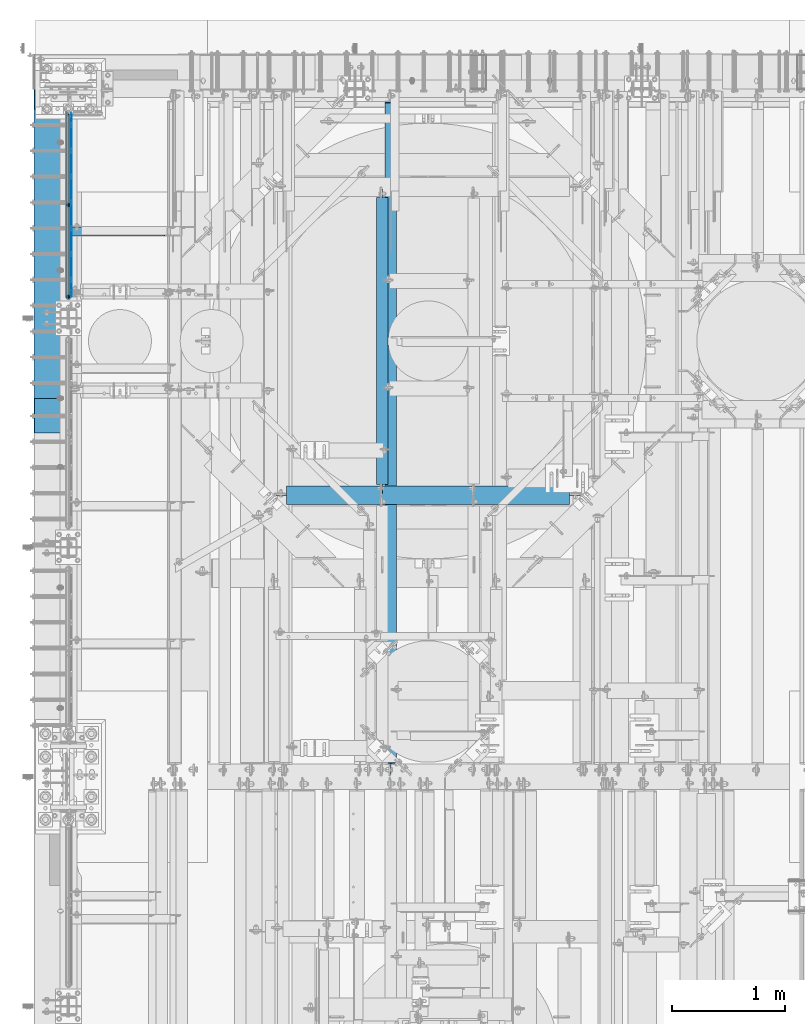
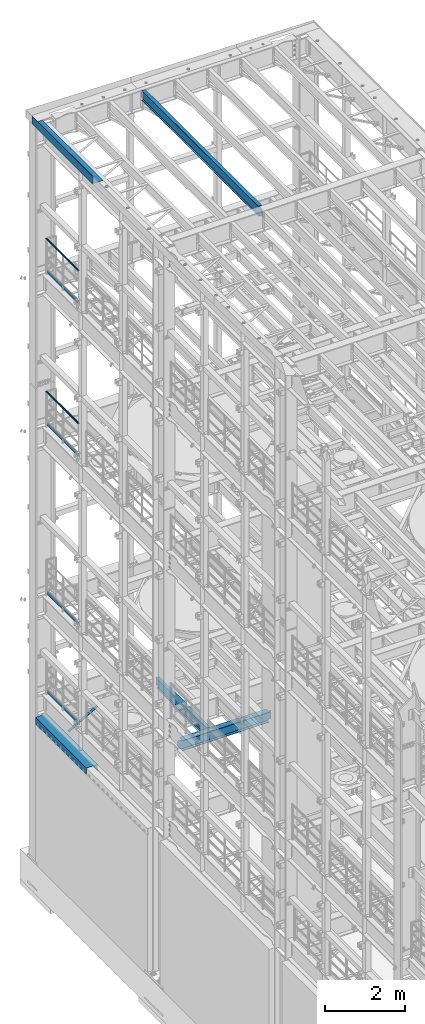
# One storey, part 1052 of 1876: 11 beams, 1 member, 10 elements without a shape of their own.
"""IFC2X3 building model written with IfcOpenShell, lengths in millimetres."""

from ifc_helpers import new_model, si_unit, frame, origin_with_axes, place, context, subcontext, project, spatial, faceted_brep, material, type_object, element, aggregate, save


model = new_model("IFC2X3")

# Units and contexts
model_context = context("Model", 3, precision=1e-05, world=origin_with_axes())
body_context = subcontext(model_context, "Body", "Model", "MODEL_VIEW")
ifc_project = project(units=[si_unit("LENGTHUNIT", "METRE", prefix="MILLI"), si_unit("AREAUNIT", "SQUARE_METRE"), si_unit("VOLUMEUNIT", "CUBIC_METRE"), si_unit("MASSUNIT", "GRAM", prefix="KILO"), si_unit("TIMEUNIT", "SECOND"), si_unit("PLANEANGLEUNIT", "RADIAN"), si_unit("SOLIDANGLEUNIT", "STERADIAN"), si_unit("THERMODYNAMICTEMPERATUREUNIT", "DEGREE_CELSIUS"), si_unit("LUMINOUSINTENSITYUNIT", "LUMEN")], contexts=[model_context])

# Site, building, storey
site_placement = place(None, origin_with_axes())
site = spatial("IfcSite", under=ifc_project, at=site_placement, CompositionType="ELEMENT")
building_placement = place(site_placement, origin_with_axes())
building = spatial("IfcBuilding", under=site, at=building_placement, Name="Undefined", CompositionType="ELEMENT")
storey_placement = place(building_placement, origin_with_axes())
storey = spatial("IfcBuildingStorey", under=building, at=storey_placement, Name="Undefined", CompositionType="ELEMENT", Elevation=0.0)

# Assembly, beam
assembly_1_placement = place(storey_placement, origin_with_axes())
assembly_1 = element("IfcElementAssembly", 1, at=assembly_1_placement, inside=storey, Name="RAIL", AssemblyPlace="NOTDEFINED", PredefinedType="RIGID_FRAME")
ifc_material_1 = material()
beam_type_1 = type_object("IfcBeamType", Name="PIPE1-1/2SCH40", PredefinedType="NOTDEFINED")
beam_1_placement = place(assembly_1_placement, frame((-1.70530256582424e-11, 11848.7825, 19059.525), z_axis=(0.0, 0.0, -1.0), x_axis=(0.0, 1.0, 0.0)))
beam_1 = element("IfcBeam", 2, at=beam_1_placement, type_object=beam_type_1, material=ifc_material_1, Name="RAIL", ObjectType="PIPE1-1/2SCH40", context=body_context, shape_type="Brep", body=[
    faceted_brep([(24.1300000000001, -20.4469999999999, 0.0), (34.3535000000002, -17.7076214311803, 10.2235000000001), (1668.63142143118, -17.7076214311804, 10.2235000000001), (1671.3708, -20.447, 0.0), (41.8376214311802, -10.2235000000001, 17.7076214311819), (1661.1473, -10.2235, 17.7076214311819), (44.5770000000002, 0.0, 20.4470000000001), (1650.9238, 0.0, 20.4470000000001), (41.8376214311802, 10.2235000000001, 17.7076214311819), (1640.7003, 10.2235, 17.7076214311819), (34.3535000000002, 17.7076214311803, 10.2235000000001), (1633.21617856882, 17.7076214311804, 10.2235000000001), (24.1300000000001, 20.4469999999999, 0.0), (1630.4768, 20.447, 0.0), (13.9065000000001, 17.7076214311803, -10.2235000000001), (1633.21617856882, 17.7076214311804, -10.2235000000001), (6.42237856882002, 10.2235000000001, -17.7076214311819), (1640.7003, 10.2235, -17.7076214311819), (3.68299999999999, 0.0, -20.4470000000001), (1650.9238, 0.0, -20.4470000000001), (6.42237856882002, -10.2235000000001, -17.7076214311819), (1661.1473, -10.2235, -17.7076214311819), (13.9065000000001, -17.7076214311803, -10.2235000000001), (1668.63142143118, -17.7076214311804, -10.2235000000001), (24.1299999999854, -24.1299999999992, 0.0), (12.0650000000064, -20.8971929933177, -12.0649999999987), (1671.82099299332, -20.8971929933185, -12.0649999999987), (1675.0538, -24.13, 0.0), (3.23280700668147, -12.0650000000001, -20.8971929933177), (1662.9888, -12.065, -20.8971929933177), (-1.45519152283669e-11, 0.0, -24.130000000001), (1650.9238, 0.0, -24.130000000001), (3.23280700668147, 12.0650000000001, -20.8971929933177), (1638.8588, 12.065, -20.8971929933177), (12.0650000000064, 20.8971929933177, -12.0649999999987), (1630.02660700668, 20.8971929933185, -12.0649999999987), (24.1300000000047, 24.1299999999992, 0.0), (1626.7938, 24.13, 0.0), (36.1949999999997, 20.8971929933184, 12.0649999999987), (1630.02660700668, 20.8971929933185, 12.0649999999987), (45.0271929933187, 12.0650000000001, 20.8971929933177), (1638.8588, 12.065, 20.8971929933177), (48.2600000000002, 0.0, 24.130000000001), (1650.9238, 0.0, 24.130000000001), (45.0271929933187, -12.0650000000001, 20.8971929933177), (1662.9888, -12.065, 20.8971929933177), (36.1949999999997, -20.8971929933184, 12.0649999999987), (1671.82099299332, -20.8971929933185, 12.0649999999987)], [[[0, 1, 2, 3]], [[1, 4, 5, 2]], [[4, 6, 7, 5]], [[6, 8, 9, 7]], [[8, 10, 11, 9]], [[10, 12, 13, 11]], [[12, 14, 15, 13]], [[14, 16, 17, 15]], [[16, 18, 19, 17]], [[18, 20, 21, 19]], [[20, 22, 23, 21]], [[22, 0, 3, 23]], [[24, 25, 26, 27]], [[25, 28, 29, 26]], [[28, 30, 31, 29]], [[30, 32, 33, 31]], [[32, 34, 35, 33]], [[34, 36, 37, 35]], [[36, 38, 39, 37]], [[38, 40, 41, 39]], [[40, 42, 43, 41]], [[42, 44, 45, 43]], [[44, 46, 47, 45]], [[46, 24, 27, 47]], [[29, 31, 33, 35, 37, 39, 41, 43, 45, 47, 27, 26], [5, 7, 9, 11, 13, 15, 17, 19, 21, 23, 3, 2]], [[46, 44, 42, 40, 38, 36, 34, 32, 30, 28, 25, 24], [22, 20, 18, 16, 14, 12, 10, 8, 6, 4, 1, 0]]]),
])

assembly_2_placement = place(storey_placement, origin_with_axes())
assembly_2 = element("IfcElementAssembly", 3, at=assembly_2_placement, inside=storey, Name="RAIL", AssemblyPlace="NOTDEFINED", PredefinedType="RIGID_FRAME")
beam_2_placement = place(assembly_2_placement, frame((-3.29691829392686e-11, 11848.7825, 14385.925), z_axis=(0.0, 0.0, -1.0), x_axis=(0.0, 1.0, 0.0)))
beam_2 = element("IfcBeam", 4, at=beam_2_placement, type_object=beam_type_1, material=ifc_material_1, Name="RAIL", ObjectType="PIPE1-1/2SCH40", context=body_context, shape_type="Brep", body=[
    faceted_brep([(24.1300000000001, -20.4469999999999, 0.0), (34.3535000000002, -17.7076214311803, 10.2235000000001), (1668.63142143118, -17.7076214311804, 10.2235000000001), (1671.3708, -20.447, 0.0), (41.8376214311802, -10.2235000000001, 17.7076214311819), (1661.1473, -10.2235, 17.7076214311819), (44.5770000000002, 0.0, 20.4470000000001), (1650.9238, 0.0, 20.4470000000001), (41.8376214311802, 10.2235000000001, 17.7076214311819), (1640.7003, 10.2235, 17.7076214311819), (34.3535000000002, 17.7076214311803, 10.2235000000001), (1633.21617856882, 17.7076214311804, 10.2235000000001), (24.1300000000001, 20.4469999999999, 0.0), (1630.4768, 20.447, 0.0), (13.9065000000001, 17.7076214311803, -10.2235000000001), (1633.21617856882, 17.7076214311804, -10.2235000000001), (6.42237856882002, 10.2235000000001, -17.7076214311819), (1640.7003, 10.2235, -17.7076214311819), (3.68299999999999, 0.0, -20.4470000000001), (1650.9238, 0.0, -20.4470000000001), (6.42237856882002, -10.2235000000001, -17.7076214311819), (1661.1473, -10.2235, -17.7076214311819), (13.9065000000001, -17.7076214311803, -10.2235000000001), (1668.63142143118, -17.7076214311804, -10.2235000000001), (24.1299999999854, -24.1299999999992, 0.0), (12.0650000000064, -20.8971929933177, -12.0649999999987), (1671.82099299332, -20.8971929933185, -12.0649999999987), (1675.0538, -24.13, 0.0), (3.23280700668147, -12.0650000000001, -20.8971929933177), (1662.9888, -12.065, -20.8971929933177), (-1.45519152283669e-11, 0.0, -24.130000000001), (1650.9238, 0.0, -24.130000000001), (3.23280700668147, 12.0650000000001, -20.8971929933177), (1638.8588, 12.065, -20.8971929933177), (12.0650000000064, 20.8971929933177, -12.0649999999987), (1630.02660700668, 20.8971929933185, -12.0649999999987), (24.1300000000047, 24.1299999999992, 0.0), (1626.7938, 24.13, 0.0), (36.1949999999997, 20.8971929933184, 12.0649999999987), (1630.02660700668, 20.8971929933185, 12.0649999999987), (45.0271929933187, 12.0650000000001, 20.8971929933177), (1638.8588, 12.065, 20.8971929933177), (48.2600000000002, 0.0, 24.130000000001), (1650.9238, 0.0, 24.130000000001), (45.0271929933187, -12.0650000000001, 20.8971929933177), (1662.9888, -12.065, 20.8971929933177), (36.1949999999997, -20.8971929933184, 12.0649999999987), (1671.82099299332, -20.8971929933185, 12.0649999999987)], [[[0, 1, 2, 3]], [[1, 4, 5, 2]], [[4, 6, 7, 5]], [[6, 8, 9, 7]], [[8, 10, 11, 9]], [[10, 12, 13, 11]], [[12, 14, 15, 13]], [[14, 16, 17, 15]], [[16, 18, 19, 17]], [[18, 20, 21, 19]], [[20, 22, 23, 21]], [[22, 0, 3, 23]], [[24, 25, 26, 27]], [[25, 28, 29, 26]], [[28, 30, 31, 29]], [[30, 32, 33, 31]], [[32, 34, 35, 33]], [[34, 36, 37, 35]], [[36, 38, 39, 37]], [[38, 40, 41, 39]], [[40, 42, 43, 41]], [[42, 44, 45, 43]], [[44, 46, 47, 45]], [[46, 24, 27, 47]], [[29, 31, 33, 35, 37, 39, 41, 43, 45, 47, 27, 26], [5, 7, 9, 11, 13, 15, 17, 19, 21, 23, 3, 2]], [[46, 44, 42, 40, 38, 36, 34, 32, 30, 28, 25, 24], [22, 20, 18, 16, 14, 12, 10, 8, 6, 4, 1, 0]]]),
])

# Beam
ifc_material_2 = material(Name="STEEL/A36")
beam_type_2 = type_object("IfcBeamType", PredefinedType="NOTDEFINED")
beam_3_placement = place(assembly_1_placement, frame((27.3049999999948, 11872.9125, 18049.875), z_axis=(0.0, 0.0, 1.0), x_axis=(0.0, 1.0, 0.0)))
beam_3 = element("IfcBeam", 5, at=beam_3_placement, type_object=beam_type_2, material=ifc_material_2, Name="PLATE", context=body_context, shape_type="Brep", body=[
    faceted_brep([(0.0, 3.17500000000018, -50.8000000000002), (0.0, 3.17500000000018, 50.8000000000002), (1626.7938, 3.175, 50.7999999999993), (1626.7938, 3.175, -50.7999999999993), (0.0, -3.17500000000018, 50.8000000000002), (1626.7938, -3.175, 50.7999999999993), (0.0, -3.17500000000018, -50.8000000000002), (1626.7938, -3.175, -50.7999999999993)], [[[0, 1, 2, 3]], [[1, 4, 5, 2]], [[4, 6, 7, 5]], [[6, 0, 3, 7]], [[5, 7, 3, 2]], [[6, 4, 1, 0]]]),
])

aggregate(assembly_1, [beam_3, beam_1])

beam_4_placement = place(assembly_2_placement, frame((27.3049999999948, 11872.9125, 13376.275), z_axis=(0.0, 0.0, 1.0), x_axis=(0.0, 1.0, 0.0)))
beam_4 = element("IfcBeam", 6, at=beam_4_placement, type_object=beam_type_2, material=ifc_material_2, Name="PLATE", context=body_context, shape_type="Brep", body=[
    faceted_brep([(0.0, 3.17500000000018, -50.8000000000002), (0.0, 3.17500000000018, 50.8000000000002), (1626.7938, 3.175, 50.7999999999993), (1626.7938, 3.175, -50.7999999999993), (0.0, -3.17500000000018, 50.8000000000002), (1626.7938, -3.175, 50.7999999999993), (0.0, -3.17500000000018, -50.8000000000002), (1626.7938, -3.175, -50.7999999999993)], [[[0, 1, 2, 3]], [[1, 4, 5, 2]], [[4, 6, 7, 5]], [[6, 0, 3, 7]], [[5, 7, 3, 2]], [[6, 4, 1, 0]]]),
])

aggregate(assembly_2, [beam_4, beam_2])

# Assembly, beam
assembly_3_placement = place(storey_placement, origin_with_axes())
assembly_3 = element("IfcElementAssembly", 7, at=assembly_3_placement, inside=storey, Name="RAIL", AssemblyPlace="NOTDEFINED", PredefinedType="RIGID_FRAME")
beam_5_placement = place(assembly_3_placement, frame((27.3049999999948, 11872.9125, 8220.075), z_axis=(0.0, 0.0, 1.0), x_axis=(0.0, 1.0, 0.0)))
beam_5 = element("IfcBeam", 8, at=beam_5_placement, type_object=beam_type_2, material=ifc_material_2, Name="PLATE", context=body_context, shape_type="Brep", body=[
    faceted_brep([(0.0, 3.17500000000018, -50.8000000000002), (0.0, 3.17500000000018, 50.8000000000002), (1626.7938, 3.175, 50.7999999999993), (1626.7938, 3.175, -50.7999999999993), (0.0, -3.17500000000018, 50.8000000000002), (1626.7938, -3.175, 50.7999999999993), (0.0, -3.17500000000018, -50.8000000000002), (1626.7938, -3.175, -50.7999999999993)], [[[0, 1, 2, 3]], [[1, 4, 5, 2]], [[4, 6, 7, 5]], [[6, 0, 3, 7]], [[5, 7, 3, 2]], [[6, 4, 1, 0]]]),
])
aggregate(assembly_3, [beam_5])

assembly_4_placement = place(storey_placement, origin_with_axes())
assembly_4 = element("IfcElementAssembly", 9, at=assembly_4_placement, inside=storey, Name="RAIL", AssemblyPlace="NOTDEFINED", PredefinedType="RIGID_FRAME")
beam_6_placement = place(assembly_4_placement, frame((27.3049999999948, 11872.9125, 5197.475), z_axis=(0.0, 0.0, 1.0), x_axis=(0.0, 1.0, 0.0)))
beam_6 = element("IfcBeam", 10, at=beam_6_placement, type_object=beam_type_2, material=ifc_material_2, Name="PLATE", context=body_context, shape_type="Brep", body=[
    faceted_brep([(0.0, 3.17500000000018, -50.8000000000002), (0.0, 3.17500000000018, 50.8000000000002), (1626.7938, 3.175, 50.7999999999993), (1626.7938, 3.175, -50.7999999999993), (0.0, -3.17500000000018, 50.8000000000002), (1626.7938, -3.175, 50.7999999999993), (0.0, -3.17500000000018, -50.8000000000002), (1626.7938, -3.175, -50.7999999999993)], [[[0, 1, 2, 3]], [[1, 4, 5, 2]], [[4, 6, 7, 5]], [[6, 0, 3, 7]], [[5, 7, 3, 2]], [[6, 4, 1, 0]]]),
])
aggregate(assembly_4, [beam_6])

# Assembly, member
assembly_5_placement = place(storey_placement, origin_with_axes())
assembly_5 = element("IfcElementAssembly", 11, at=assembly_5_placement, inside=storey, AssemblyPlace="NOTDEFINED", PredefinedType="RIGID_FRAME")
member_type = type_object("IfcMemberType", Name="L3X3X3/8", PredefinedType="NOTDEFINED")
member_placement = place(assembly_5_placement, frame((19.2391985516099, 12449.175, 4577.2144175513), z_axis=(0.0, -1.0, 0.0), x_axis=(0.863139327949449, 0.0, 0.50496584097043)))
member = element("IfcMember", 12, at=member_placement, type_object=member_type, material=ifc_material_2, ObjectType="L3X3X3/8", context=body_context, shape_type="Brep", body=[
    faceted_brep([(22.9902048797903, -38.0999999999885, -38.1000000000004), (22.9902048797903, -38.0999999999885, -28.5750000000007), (22.9902048798026, 28.5750000000021, -28.5750000000007), (22.9902048798026, 28.5750000000021, 38.1000000000004), (22.990204879804, 38.0999999999999, 38.1000000000004), (22.990204879804, 38.0999999999999, -38.1000000000004), (987.145928714758, 28.5750000002508, 38.1000000000004), (987.145928714761, 38.10000000025, 38.1000000000004), (987.145928714761, 38.10000000025, -38.1000000000004), (987.145928714736, -38.0999999997393, -38.1000000000004), (987.145928714736, -38.0999999997393, -28.5750000000007), (987.145928714758, 28.5750000002508, -28.5750000000007)], [[[0, 1, 2, 3, 4, 5]], [[4, 3, 6, 7]], [[5, 4, 7, 8]], [[0, 5, 8, 9]], [[1, 0, 9, 10]], [[2, 1, 10, 11]], [[3, 2, 11, 6]], [[10, 9, 8, 7, 6, 11]]]),
])
aggregate(assembly_5, [member])

# Assembly, beam
assembly_6_placement = place(storey_placement, origin_with_axes())
assembly_6 = element("IfcElementAssembly", 13, at=assembly_6_placement, inside=storey, Name="BEAM", AssemblyPlace="NOTDEFINED", PredefinedType="RIGID_FRAME")
ifc_material_3 = material(Name="STEEL/A992")
beam_type_3 = type_object("IfcBeamType", Name="W12X16", PredefinedType="NOTDEFINED")
beam_7_placement = place(assembly_6_placement, frame((2781.3, 10115.55, 4978.4), z_axis=(0.0, 0.0, 1.0), x_axis=(0.0, 1.0, 0.0)))
beam_7 = element("IfcBeam", 14, at=beam_7_placement, type_object=beam_type_3, material=ifc_material_3, Name="BEAM", ObjectType="W12X16", context=body_context, shape_type="Brep", body=[
    faceted_brep([(15.8749999999982, -3.17500000000018, -127.0), (15.8749999999982, 3.17500000000018, -127.0), (98.425000190733, 3.17500000000018, -127.0), (98.425000190733, -3.17500000000018, -127.0), (103.285079708779, 3.17500000000018, -127.966729922588), (103.285079708779, -3.17500000000018, -127.966729922588), (107.405256176932, 3.17500000000018, -130.719743823065), (107.405256176932, -3.17500000000018, -130.719743823065), (110.158270077411, 3.17500000000018, -134.839920291219), (110.158270077411, -3.17500000000018, -134.839920291219), (111.124999999998, -3.17500000000018, -139.699999809265), (111.124999999998, 3.17500000000018, -139.699999809265), (111.124999999998, 3.17500000000018, -146.049999999999), (111.124999999998, 50.8000000000002, -146.049999999999), (111.124999999998, 50.8000000000002, -152.400000000001), (111.124999999998, -50.8000000000002, -152.400000000001), (111.124999999998, -50.8000000000002, -146.049999999999), (111.124999999998, -3.17500000000018, -146.049999999999), (2638.42499999958, 50.8000000000002, 146.05), (2638.42499999958, 3.17500000000018, 146.05), (92.0750000000044, 3.17500000000018, 146.05), (92.0750000000044, 50.8000000000002, 146.05), (79.3750001907392, -3.17500000000018, 127.000000000001), (79.3750001907392, 3.17500000000018, 127.000000000001), (15.875, 3.17500000000018, 127.000000000001), (15.875, -3.17500000000018, 127.000000000001), (84.2350797087856, -3.17500000000018, 127.966729922588), (84.2350797087856, 3.17500000000018, 127.966729922588), (88.3552561769393, -3.17500000000018, 130.719743823067), (88.3552561769393, 3.17500000000018, 130.719743823067), (91.1082700774168, -3.17500000000018, 134.839920291221), (91.1082700774168, 3.17500000000018, 134.839920291221), (92.0750000000044, -3.17500000000018, 139.699999809266), (92.0750000000044, 3.17500000000018, 139.699999809266), (2638.42499999958, -50.8000000000002, 152.4), (2638.42499999958, 50.8000000000002, 152.4), (92.0750000000044, 50.8000000000002, 152.4), (92.0750000000044, -50.8000000000002, 152.4), (2638.42499999958, -50.8000000000002, 146.05), (92.0750000000044, -50.8000000000002, 146.05), (2638.42499999958, -3.17500000000018, 146.05), (92.0750000000044, -3.17500000000018, 146.05), (2638.42499999958, -3.17500000000018, 139.699999809266), (2638.42499999958, 3.17500000000018, 139.699999809266), (2639.39172992217, -3.17500000000018, 134.839920291221), (2639.39172992217, 3.17500000000018, 134.839920291221), (2642.14474382265, -3.17500000000018, 130.719743823067), (2642.14474382265, 3.17500000000018, 130.719743823067), (2646.2649202908, -3.17500000000018, 127.966729922588), (2646.2649202908, 3.17500000000018, 127.966729922588), (2651.12499980885, -3.17500000000018, 127.000000000001), (2651.12499980885, 3.17500000000018, 127.000000000001), (2714.62499999958, -3.17500000000018, 127.000000000001), (2714.62499999958, 3.17500000000018, 127.000000000001), (2714.62499999958, -3.17500000000018, -126.999999999999), (2714.62499999958, 3.17500000000018, -126.999999999999), (2632.07499980885, -3.17500000000018, -126.999999999999), (2632.07499980885, 3.17500000000018, -126.999999999999), (2627.2149202908, -3.17500000000018, -127.966729922587), (2627.2149202908, 3.17500000000018, -127.966729922587), (2623.09474382265, -3.17500000000018, -130.719743823065), (2623.09474382265, 3.17500000000018, -130.719743823065), (2620.34172992217, -3.17500000000018, -134.839920291219), (2620.34172992217, 3.17500000000018, -134.839920291219), (2619.37499999958, -3.17500000000018, -139.699999809264), (2619.37499999958, 3.17500000000018, -139.699999809264), (2619.37499999958, -3.17500000000018, -146.05), (2619.37499999958, -50.8000000000002, -146.05), (2619.37499999958, -50.8000000000002, -152.4), (2619.37499999958, 50.8000000000002, -152.4), (2619.37499999958, 50.8000000000002, -146.05), (2619.37499999958, 3.17500000000018, -146.05)], [[[0, 1, 2, 3]], [[3, 2, 4, 5]], [[5, 4, 6, 7]], [[7, 6, 8, 9]], [[10, 11, 12, 13, 14, 15, 16, 17]], [[9, 8, 11, 10]], [[18, 19, 20, 21]], [[22, 23, 24, 25]], [[26, 27, 23, 22]], [[28, 29, 27, 26]], [[30, 31, 29, 28]], [[32, 33, 31, 30]], [[34, 35, 36, 37]], [[38, 34, 37, 39]], [[40, 38, 39, 41]], [[37, 36, 21, 20, 33, 32, 41, 39]], [[35, 18, 21, 36]], [[34, 38, 40, 42, 43, 19, 18, 35]], [[44, 45, 43, 42]], [[46, 47, 45, 44]], [[48, 49, 47, 46]], [[50, 51, 49, 48]], [[52, 53, 51, 50]], [[53, 52, 54, 55]], [[54, 56, 57, 55]], [[58, 59, 57, 56]], [[60, 61, 59, 58]], [[62, 63, 61, 60]], [[64, 65, 63, 62]], [[66, 67, 68, 69, 70, 71, 65, 64]], [[67, 66, 17, 16]], [[68, 67, 16, 15]], [[69, 68, 15, 14]], [[70, 69, 14, 13]], [[71, 70, 13, 12]], [[6, 4, 2, 1, 24, 23, 27, 29, 31, 33, 20, 19, 43, 45, 47, 49, 51, 53, 55, 57, 59, 61, 63, 65, 71, 12, 11, 8]], [[25, 24, 1, 0]], [[66, 64, 62, 60, 58, 56, 54, 52, 50, 48, 46, 44, 42, 40, 41, 32, 30, 28, 26, 22, 25, 0, 3, 5, 7, 9, 10, 17]]]),
])
aggregate(assembly_6, [beam_7])

assembly_7_placement = place(storey_placement, origin_with_axes())
assembly_7 = element("IfcElementAssembly", 15, at=assembly_7_placement, inside=storey, Name="BEAM", AssemblyPlace="NOTDEFINED", PredefinedType="RIGID_FRAME")
beam_8_placement = place(assembly_7_placement, frame((2857.5, 7620.0, 22402.8), z_axis=(0.0, 0.0, 1.0), x_axis=(0.0, 1.0, 0.0)))
beam_8 = element("IfcBeam", 16, at=beam_8_placement, type_object=beam_type_3, material=ifc_material_3, Name="BEAM", ObjectType="W12X16", context=body_context, shape_type="Brep", body=[
    faceted_brep([(19.84375, -3.17499999999995, -126.999999999996), (19.84375, 3.17499999999995, -126.999999999996), (102.393750190735, 3.17500000000018, -127.000000000001), (102.393750190735, -3.17500000000018, -127.000000000001), (107.25382970878, 3.17500000000018, -127.966729922588), (107.25382970878, -3.17500000000018, -127.966729922588), (111.374006176934, 3.17500000000018, -130.719743823067), (111.374006176934, -3.17500000000018, -130.719743823067), (114.127020077412, 3.17500000000018, -134.839920291221), (114.127020077412, -3.17500000000018, -134.839920291221), (115.09375, -3.17500000000018, -139.699999809266), (115.09375, 3.17500000000018, -139.699999809266), (115.09375, 3.17500000000018, -146.05), (115.09375, 50.8000000000002, -146.05), (115.09375, 50.8000000000002, -152.4), (115.09375, -50.8000000000002, -152.4), (115.09375, -50.8000000000002, -146.05), (115.09375, -3.17500000000018, -146.05), (127.79375, 3.17500000000018, 146.05), (127.79375, 50.8000000000002, 146.05), (5968.20625, 50.8, 146.05), (5968.20625, 3.17499999999995, 146.05), (115.093750190735, -3.17500000000018, 114.299999999999), (115.093750190735, 3.17500000000018, 114.299999999999), (19.84375, 3.17500000000018, 114.299999999999), (19.84375, -3.17500000000018, 114.299999999999), (119.95382970878, -3.17500000000018, 115.266729922587), (119.95382970878, 3.17500000000018, 115.266729922587), (124.074006176934, -3.17500000000018, 118.019743823065), (124.074006176934, 3.17500000000018, 118.019743823065), (126.827020077412, -3.17500000000018, 122.139920291219), (126.827020077412, 3.17500000000018, 122.139920291219), (127.79375, -3.17500000000018, 126.999999809264), (127.79375, 3.17500000000018, 126.999999809264), (127.79375, 50.8000000000002, 152.4), (127.79375, -50.8000000000002, 152.4), (5968.20625, -50.8, 152.4), (5968.20625, 50.8, 152.4), (127.79375, -50.8000000000002, 146.05), (5968.20625, -50.8, 146.05), (127.79375, -3.17500000000018, 146.05), (5968.20625, -3.17499999999995, 146.05), (5968.20625, -3.17499999999995, 126.999999809264), (5968.20625, 3.17499999999995, 126.999999809264), (5969.17297992259, -3.17499999999995, 122.139920291219), (5969.17297992259, 3.17499999999995, 122.139920291219), (5971.92599382307, -3.17499999999995, 118.019743823065), (5971.92599382307, 3.17499999999995, 118.019743823065), (5976.04617029122, -3.17499999999995, 115.266729922587), (5976.04617029122, 3.17499999999995, 115.266729922587), (5980.90624980927, -3.17499999999995, 114.299999999999), (5980.90624980927, 3.17499999999995, 114.299999999999), (6076.15625, -3.17499999999995, 114.299999999999), (6076.15625, 3.17499999999995, 114.299999999999), (6076.15625, -3.17499999999995, -126.999999999996), (6076.15625, 3.17499999999995, -126.999999999996), (5993.60624980927, -3.17499999999995, -127.000000000001), (5993.60624980927, 3.17499999999995, -127.000000000001), (5988.74617029122, -3.17499999999995, -127.966729922588), (5988.74617029122, 3.17499999999995, -127.966729922588), (5984.62599382307, -3.17499999999995, -130.719743823067), (5984.62599382307, 3.17499999999995, -130.719743823067), (5981.87297992259, -3.17499999999995, -134.839920291221), (5981.87297992259, 3.17499999999995, -134.839920291221), (5980.90625, -3.17499999999995, -139.699999809266), (5980.90625, 3.17499999999995, -139.699999809266), (5980.90625, -3.17499999999995, -146.05), (5980.90625, -50.8, -146.05), (5980.90625, -50.8, -152.4), (5980.90625, 50.8, -152.4), (5980.90625, 50.8, -146.05), (5980.90625, 3.17499999999995, -146.05)], [[[0, 1, 2, 3]], [[3, 2, 4, 5]], [[5, 4, 6, 7]], [[7, 6, 8, 9]], [[10, 11, 12, 13, 14, 15, 16, 17]], [[9, 8, 11, 10]], [[18, 19, 20, 21]], [[22, 23, 24, 25]], [[26, 27, 23, 22]], [[28, 29, 27, 26]], [[30, 31, 29, 28]], [[32, 33, 31, 30]], [[34, 35, 36, 37]], [[35, 38, 39, 36]], [[38, 40, 41, 39]], [[35, 34, 19, 18, 33, 32, 40, 38]], [[19, 34, 37, 20]], [[36, 39, 41, 42, 43, 21, 20, 37]], [[44, 45, 43, 42]], [[46, 47, 45, 44]], [[48, 49, 47, 46]], [[50, 51, 49, 48]], [[52, 53, 51, 50]], [[53, 52, 54, 55]], [[54, 56, 57, 55]], [[58, 59, 57, 56]], [[60, 61, 59, 58]], [[62, 63, 61, 60]], [[64, 65, 63, 62]], [[66, 67, 68, 69, 70, 71, 65, 64]], [[17, 16, 67, 66]], [[16, 15, 68, 67]], [[15, 14, 69, 68]], [[14, 13, 70, 69]], [[13, 12, 71, 70]], [[59, 61, 63, 65, 71, 12, 11, 8, 6, 4, 2, 1, 24, 23, 27, 29, 31, 33, 18, 21, 43, 45, 47, 49, 51, 53, 55, 57]], [[25, 24, 1, 0]], [[52, 50, 48, 46, 44, 42, 41, 40, 32, 30, 28, 26, 22, 25, 0, 3, 5, 7, 9, 10, 17, 66, 64, 62, 60, 58, 56, 54]]]),
])
aggregate(assembly_7, [beam_8])

assembly_8_placement = place(storey_placement, origin_with_axes())
assembly_8 = element("IfcElementAssembly", 17, at=assembly_8_placement, inside=storey, Name="BENT PLATE", AssemblyPlace="NOTDEFINED", PredefinedType="RIGID_FRAME")
beam_type_4 = type_object("IfcBeamType", PredefinedType="NOTDEFINED")
beam_9_placement = place(assembly_8_placement, frame((2.28578142867657e-05, 12192.0, 22558.3750000001), z_axis=(0.0, 1.0, 0.0), x_axis=(-0.999999999968684, 0.0, -7.91400000071008e-06)))
beam_9 = element("IfcBeam", 18, at=beam_9_placement, type_object=beam_type_4, material=ifc_material_2, Name="BENT PLATE", context=body_context, shape_type="Brep", body=[
    faceted_brep([(9.877112461254e-10, -3.17499999999563, -1524.0), (9.877112461254e-10, -3.17499999999563, 1524.0), (-9.88620740827173e-10, 3.17500000000291, 1524.0), (-9.88620740827173e-10, 3.17500000000291, -1524.0), (298.449951181141, 3.17499990714714, 1524.0), (298.449951181141, 3.17499990714714, -1524.0), (304.799984389467, -3.1750000948341, -1524.0), (304.799984389467, -3.1750000948341, 1524.0), (298.448604036157, 236.934945778325, 1524.0), (298.448604036646, 236.934945778212, -1524.0), (304.798604036052, 236.934982372997, 1524.0), (304.798604036541, 236.934982372881, -1524.0)], [[[0, 1, 2, 3]], [[3, 2, 4, 5]], [[1, 0, 6, 7]], [[5, 4, 8, 9]], [[4, 2, 1, 7, 10, 8]], [[7, 6, 11, 10]], [[6, 0, 3, 5, 9, 11]], [[10, 11, 9, 8]]]),
])
aggregate(assembly_8, [beam_9])

assembly_9_placement = place(storey_placement, origin_with_axes())
assembly_9 = element("IfcElementAssembly", 19, at=assembly_9_placement, inside=storey, Name="BENT PLATE", AssemblyPlace="NOTDEFINED", PredefinedType="RIGID_FRAME")
beam_type_5 = type_object("IfcBeamType", PredefinedType="NOTDEFINED")
beam_10_placement = place(assembly_9_placement, frame((-298.449987792968, 12252.325, 4305.30000305175), z_axis=(0.0, 1.0, 0.0), x_axis=(0.0, 0.0, 1.0)))
beam_10 = element("IfcBeam", 20, at=beam_10_placement, type_object=beam_type_5, material=ifc_material_2, Name="BENT PLATE", context=body_context, shape_type="Brep", body=[
    faceted_brep([(0.0, -6.35000000000002, -1282.7), (0.0, -6.35000000000002, 1282.7), (0.0, 6.35000000000002, 1282.7), (0.0, 6.35000000000002, -1282.7), (190.499996948253, 6.35000000000088, 1282.7), (190.499996948253, 6.35000000000088, -1282.7), (203.199996948254, -6.34999999999911, -1282.7), (203.199996948254, -6.34999999999911, 1282.7), (190.499996948253, 303.212481689453, 1282.7), (190.499996948253, 303.212481689453, -1282.7), (203.199996948254, 315.912481689453, -1282.7), (203.199996948254, 315.912481689453, 1282.7), (2.45563569478691e-11, 303.212481689453, 1282.7), (2.45563569478691e-11, 303.212481689453, -1282.7), (2.45563569478691e-11, 315.912481689453, 1282.7), (2.45563569478691e-11, 315.912481689453, -1282.7)], [[[0, 1, 2, 3]], [[3, 2, 4, 5]], [[1, 0, 6, 7]], [[5, 4, 8, 9]], [[7, 6, 10, 11]], [[9, 8, 12, 13]], [[8, 4, 2, 1, 7, 11, 14, 12]], [[11, 10, 15, 14]], [[10, 6, 0, 3, 5, 9, 13, 15]], [[14, 15, 13, 12]]]),
])
aggregate(assembly_9, [beam_10])

assembly_10_placement = place(storey_placement, origin_with_axes())
assembly_10 = element("IfcElementAssembly", 21, at=assembly_10_placement, inside=storey, Name="BEAM", AssemblyPlace="NOTDEFINED", PredefinedType="RIGID_FRAME")
beam_type_6 = type_object("IfcBeamType", Name="W12X30", PredefinedType="NOTDEFINED")
beam_11_placement = place(assembly_10_placement, frame((1866.9, 10115.55, 4973.6375), z_axis=(0.0, 0.0, 1.0), x_axis=(1.0, 0.0, 0.0)))
beam_11 = element("IfcBeam", 22, at=beam_11_placement, type_object=beam_type_6, material=ifc_material_3, Name="BEAM", ObjectType="W12X30", context=body_context, shape_type="Brep", body=[
    faceted_brep([(2574.925, -3.17499999999927, -146.05), (2574.925, -82.5499999999993, -146.05), (2574.925, -82.5499999999993, -157.1625), (2574.925, 82.5499999999993, -157.1625), (2574.925, 82.5499999999993, -146.05), (2574.925, 3.17499999999927, -146.05), (2574.925, 3.17499999999927, -144.462499809264), (2574.925, -3.17499999999927, -144.462499809264), (2575.89172992259, 3.17499999999927, -139.602420291219), (2575.89172992259, -3.17499999999927, -139.602420291219), (2578.64474382307, 3.17499999999927, -135.482243823065), (2578.64474382307, -3.17499999999927, -135.482243823065), (2582.76492029122, 3.17499999999927, -132.729229922586), (2582.76492029122, -3.17499999999927, -132.729229922586), (2587.62499980927, 3.17499999999927, -131.762499999999), (2587.62499980927, -3.17499999999927, -131.762499999999), (2670.175, -3.17499999999927, -131.762499999999), (2670.175, 3.17499999999927, -131.762499999999), (66.6750000000002, 3.17500000000018, 146.049999999999), (66.6749999999975, 82.5499999999993, 146.05), (2574.925, 82.5499999999993, 146.05), (2574.925, 3.17499999999927, 146.05), (66.6749999999975, -3.17499999999927, -144.462499809264), (66.6749999999975, 3.17499999999927, -144.462499809264), (66.6750000000002, 3.17500000000018, -146.049999999999), (66.6749999999975, 82.5499999999993, -146.05), (66.6749999999975, 82.5499999999993, -157.1625), (66.6749999999975, -82.5499999999993, -157.1625), (66.6749999999975, -82.5499999999993, -146.05), (66.6750000000002, -3.17500000000018, -146.049999999999), (65.7082700774097, -3.17499999999927, -139.602420291219), (65.7082700774097, 3.17499999999927, -139.602420291219), (62.9552561769315, -3.17499999999927, -135.482243823065), (62.9552561769315, 3.17499999999927, -135.482243823065), (58.8350797087778, -3.17499999999927, -132.729229922586), (58.8350797087778, 3.17499999999927, -132.729229922586), (53.9750001907323, -3.17499999999927, -131.762499999999), (53.9750001907323, 3.17499999999927, -131.762499999999), (-28.5750000000032, -3.17499999999927, -131.762499999999), (-28.5750000000032, 3.17499999999927, -131.762499999999), (-28.5750000000032, -3.17499999999927, 131.762500000001), (-28.5750000000032, 3.17499999999927, 131.762500000001), (53.9750001907323, -3.17499999999927, 131.762500000001), (53.9750001907323, 3.17499999999927, 131.762500000001), (58.8350797087778, -3.17499999999927, 132.729229922588), (58.8350797087778, 3.17499999999927, 132.729229922588), (62.9552561769315, -3.17499999999927, 135.482243823067), (62.9552561769315, 3.17499999999927, 135.482243823067), (65.7082700774097, -3.17499999999927, 139.60242029122), (65.7082700774097, 3.17499999999927, 139.60242029122), (66.6749999999975, -3.17499999999927, 144.462499809266), (66.6749999999975, 3.17499999999927, 144.462499809266), (66.6749999999975, -82.5499999999993, 157.1625), (66.6749999999975, 82.5499999999993, 157.1625), (66.6750000000002, -3.17500000000018, 146.049999999999), (66.6749999999975, -82.5499999999993, 146.05), (2574.925, -3.17499999999927, 146.05), (2574.925, -82.5499999999993, 146.05), (2574.925, -82.5499999999993, 157.1625), (2574.925, 82.5499999999993, 157.1625), (2574.925, -3.17499999999927, 144.462499809266), (2574.925, 3.17499999999927, 144.462499809266), (2575.89172992259, -3.17499999999927, 139.60242029122), (2575.89172992259, 3.17499999999927, 139.60242029122), (2578.64474382307, -3.17499999999927, 135.482243823067), (2578.64474382307, 3.17499999999927, 135.482243823067), (2582.76492029122, -3.17499999999927, 132.729229922588), (2582.76492029122, 3.17499999999927, 132.729229922588), (2587.62499980926, -3.17499999999927, 131.762500000001), (2587.62499980926, 3.17499999999927, 131.762500000001), (2670.175, -3.17499999999927, 131.762500000001), (2670.175, 3.17499999999927, 131.762500000001)], [[[0, 1, 2, 3, 4, 5, 6, 7]], [[7, 6, 8, 9]], [[9, 8, 10, 11]], [[11, 10, 12, 13]], [[13, 12, 14, 15]], [[16, 15, 14, 17]], [[18, 19, 20, 21]], [[22, 23, 24, 25, 26, 27, 28, 29]], [[30, 31, 23, 22]], [[32, 33, 31, 30]], [[34, 35, 33, 32]], [[36, 37, 35, 34]], [[38, 39, 37, 36]], [[40, 41, 39, 38]], [[42, 43, 41, 40]], [[44, 45, 43, 42]], [[46, 47, 45, 44]], [[48, 49, 47, 46]], [[50, 51, 49, 48]], [[52, 53, 19, 18, 51, 50, 54, 55]], [[55, 54, 56, 57]], [[52, 55, 57, 58]], [[53, 52, 58, 59]], [[19, 53, 59, 20]], [[58, 57, 56, 60, 61, 21, 20, 59]], [[62, 63, 61, 60]], [[64, 65, 63, 62]], [[66, 67, 65, 64]], [[68, 69, 67, 66]], [[70, 71, 69, 68]], [[71, 70, 16, 17]], [[12, 10, 8, 6, 5, 24, 23, 31, 33, 35, 37, 39, 41, 43, 45, 47, 49, 51, 18, 21, 61, 63, 65, 67, 69, 71, 17, 14]], [[25, 24, 5, 4]], [[26, 25, 4, 3]], [[27, 26, 3, 2]], [[28, 27, 2, 1]], [[29, 28, 1, 0]], [[70, 68, 66, 64, 62, 60, 56, 54, 50, 48, 46, 44, 42, 40, 38, 36, 34, 32, 30, 22, 29, 0, 7, 9, 11, 13, 15, 16]]]),
])
aggregate(assembly_10, [beam_11])

save(model, "model.ifc")
